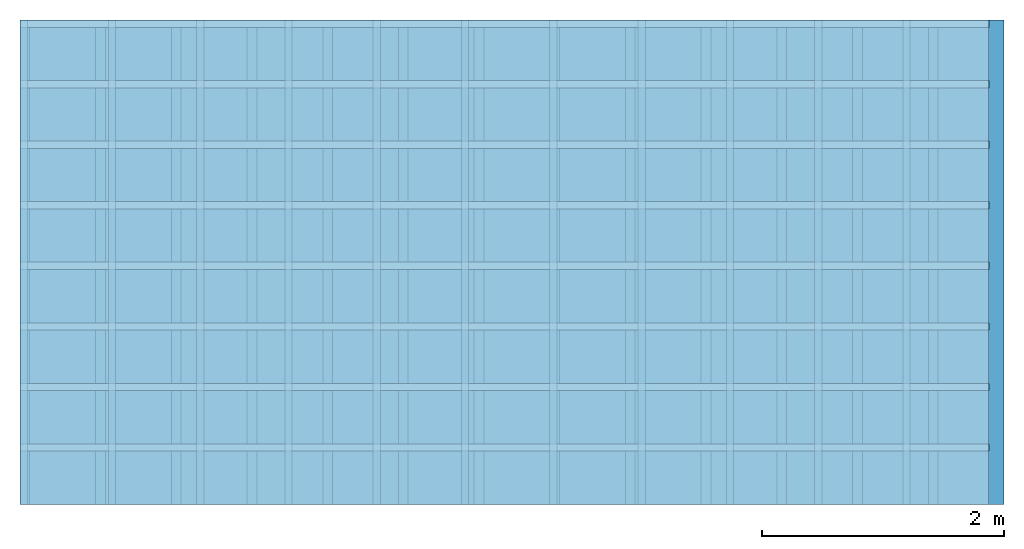
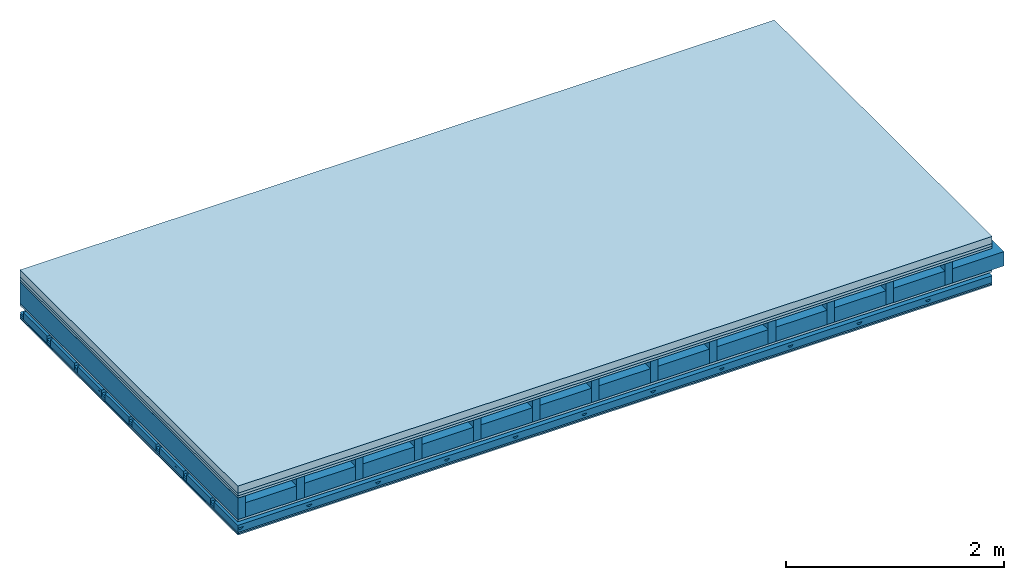
# One storey: 6 plates, 5 members, 1 element without a shape of its own.
"""IFC4 building model written with IfcOpenShell, lengths in metres."""

from ifc_helpers import new_model, si_unit, derived_unit, direction, frame, frame_2d, origin, origin_with_axes, place, context, project, spatial, polyline, rectangle, outline, extrude, material, layer, layer_set, type_object, element, aggregate, save


model = new_model("IFC4")

# Units and contexts
plan_context = context("Plan", 3, precision=1e-05, world=origin(), true_north=direction((0.0, 1.0)))
model_context = context("Model", 3, precision=1e-05, world=origin(), true_north=direction((0.0, 1.0)))
ifc_project = project(units=[si_unit("LENGTHUNIT", "METRE"), derived_unit("SOUNDPRESSUREUNIT", [(si_unit("PRESSUREUNIT", "PASCAL", prefix="MICRO"), 0)]), si_unit("ENERGYUNIT", "JOULE", prefix="MEGA"), si_unit("MASSUNIT", "GRAM", prefix="KILO"), derived_unit("THERMALTRANSMITTANCEUNIT", [(si_unit("POWERUNIT", "WATT"), 1), (si_unit("AREAUNIT", "SQUARE_METRE"), -1), (si_unit("THERMODYNAMICTEMPERATUREUNIT", "KELVIN"), -1)]), derived_unit("AREADENSITYUNIT", [(si_unit("MASSUNIT", "GRAM", prefix="KILO"), 1), (si_unit("AREAUNIT", "SQUARE_METRE"), -1)]), derived_unit("USERDEFINED", [(si_unit("ENERGYUNIT", "JOULE", prefix="MEGA"), 1), (si_unit("AREAUNIT", "SQUARE_METRE"), -1)])], contexts=[plan_context, model_context])

# Site, building, storey
site = spatial("IfcSite", under=ifc_project)
building_placement = place(None, origin())
building = spatial("IfcBuilding", under=site, at=building_placement)
storey_placement = place(building_placement, origin())
storey = spatial("IfcBuildingStorey", under=building, at=storey_placement)

# Slab, members, plates
ifc_material_1 = material(Name="Cement screed", Category="04.006")
ifc_layer_1 = layer(ifc_material_1, 0.08, Name="On-material")
ifc_material_2 = material()
ifc_layer_2 = layer(ifc_material_2, 0.03, Name="Impact sound insulation")
ifc_material_3 = material(Category="07.001")
ifc_layer_3 = layer(ifc_material_3, 0.025, Name="Sub-floor")
ifc_material_4 = material(Name="Rigid, of the art")
ifc_layer_4 = layer(ifc_material_4, 0.0, Name="Bond")
ifc_layer_5 = layer(None, 0.24, Name="Supporting structure")
ifc_layer_6 = layer(ifc_material_4, 0.0, Name="Bond")
ifc_layer_7 = layer(ifc_material_3, 0.025, Name="Lower layer 1")
ifc_layer_8 = layer(None, 0.093, Name="Coupling")
ifc_layer_9 = layer(None, 0.027, Name="Battens / profiles")
ifc_material_5 = material(Category="03.007")
ifc_layer_10 = layer(ifc_material_5, 0.015, Name="Ceiling covering 1st layer")
ifc_layer_11 = layer(ifc_material_5, 0.015, Name="Ceiling covering layer 2")
ifc_material_6 = material(Name="Glued joints")
ifc_layer_12 = layer(ifc_material_6, 0.0, Name="Surface / treatment")
ifc_layer_set = layer_set([ifc_layer_1, ifc_layer_2, ifc_layer_3, ifc_layer_4, ifc_layer_5, ifc_layer_6, ifc_layer_7, ifc_layer_8, ifc_layer_9, ifc_layer_10, ifc_layer_11, ifc_layer_12])
slab_type = type_object("IfcSlabType", Name="A0353", PredefinedType="NOTDEFINED", material=ifc_layer_set)
slab_placement = place(None, frame((0.0, 0.0, 0.0), z_axis=(0.0, 0.0, -1.0), x_axis=(1.0, 0.0, 0.0)))
slab = element("IfcSlab", 1, at=slab_placement, inside=storey, type_object=slab_type, material=ifc_layer_set, Name="Slab #1")
ifc_material_7 = material()
member_1_placement = place(slab_placement, origin())
member_1 = element("IfcMember", 2, at=member_1_placement, material=ifc_material_7, Name="Supporting structure", context=plan_context, shape_type="SweptSolid", body=[
    extrude(rectangle(XDim=0.08, YDim=0.24, at=frame_2d((0.04, 0.12), x_axis=(1.0, 0.0))), frame((0.0, 4.0, 0.135), z_axis=(0.0, -1.0, 0.0), x_axis=(1.0, 0.0, 0.0)), (0.0, 0.0, 1.0), 4.0),
    extrude(rectangle(XDim=0.08, YDim=0.24, at=frame_2d((0.04, 0.12), x_axis=(1.0, 0.0))), frame((0.625, 4.0, 0.135), z_axis=(0.0, -1.0, 0.0), x_axis=(1.0, 0.0, 0.0)), (0.0, 0.0, 1.0), 4.0),
    extrude(rectangle(XDim=0.08, YDim=0.24, at=frame_2d((0.04, 0.12), x_axis=(1.0, 0.0))), frame((1.25, 4.0, 0.135), z_axis=(0.0, -1.0, 0.0), x_axis=(1.0, 0.0, 0.0)), (0.0, 0.0, 1.0), 4.0),
    extrude(rectangle(XDim=0.08, YDim=0.24, at=frame_2d((0.04, 0.12), x_axis=(1.0, 0.0))), frame((1.875, 4.0, 0.135), z_axis=(0.0, -1.0, 0.0), x_axis=(1.0, 0.0, 0.0)), (0.0, 0.0, 1.0), 4.0),
    extrude(rectangle(XDim=0.08, YDim=0.24, at=frame_2d((0.04, 0.12), x_axis=(1.0, 0.0))), frame((2.5, 4.0, 0.135), z_axis=(0.0, -1.0, 0.0), x_axis=(1.0, 0.0, 0.0)), (0.0, 0.0, 1.0), 4.0),
    extrude(rectangle(XDim=0.08, YDim=0.24, at=frame_2d((0.04, 0.12), x_axis=(1.0, 0.0))), frame((3.125, 4.0, 0.135), z_axis=(0.0, -1.0, 0.0), x_axis=(1.0, 0.0, 0.0)), (0.0, 0.0, 1.0), 4.0),
    extrude(rectangle(XDim=0.08, YDim=0.24, at=frame_2d((0.04, 0.12), x_axis=(1.0, 0.0))), frame((3.75, 4.0, 0.135), z_axis=(0.0, -1.0, 0.0), x_axis=(1.0, 0.0, 0.0)), (0.0, 0.0, 1.0), 4.0),
    extrude(rectangle(XDim=0.08, YDim=0.24, at=frame_2d((0.04, 0.12), x_axis=(1.0, 0.0))), frame((4.375, 4.0, 0.135), z_axis=(0.0, -1.0, 0.0), x_axis=(1.0, 0.0, 0.0)), (0.0, 0.0, 1.0), 4.0),
    extrude(rectangle(XDim=0.08, YDim=0.24, at=frame_2d((0.04, 0.12), x_axis=(1.0, 0.0))), frame((5.0, 4.0, 0.135), z_axis=(0.0, -1.0, 0.0), x_axis=(1.0, 0.0, 0.0)), (0.0, 0.0, 1.0), 4.0),
    extrude(rectangle(XDim=0.08, YDim=0.24, at=frame_2d((0.04, 0.12), x_axis=(1.0, 0.0))), frame((5.625, 4.0, 0.135), z_axis=(0.0, -1.0, 0.0), x_axis=(1.0, 0.0, 0.0)), (0.0, 0.0, 1.0), 4.0),
    extrude(rectangle(XDim=0.08, YDim=0.24, at=frame_2d((0.04, 0.12), x_axis=(1.0, 0.0))), frame((6.25, 4.0, 0.135), z_axis=(0.0, -1.0, 0.0), x_axis=(1.0, 0.0, 0.0)), (0.0, 0.0, 1.0), 4.0),
    extrude(rectangle(XDim=0.08, YDim=0.24, at=frame_2d((0.04, 0.12), x_axis=(1.0, 0.0))), frame((6.875, 4.0, 0.135), z_axis=(0.0, -1.0, 0.0), x_axis=(1.0, 0.0, 0.0)), (0.0, 0.0, 1.0), 4.0),
    extrude(rectangle(XDim=0.08, YDim=0.24, at=frame_2d((0.04, 0.12), x_axis=(1.0, 0.0))), frame((7.5, 4.0, 0.135), z_axis=(0.0, -1.0, 0.0), x_axis=(1.0, 0.0, 0.0)), (0.0, 0.0, 1.0), 4.0),
])
ifc_material_8 = material()
member_2_placement = place(slab_placement, origin())
member_2 = element("IfcMember", 3, at=member_2_placement, material=ifc_material_8, Name="Cavity", context=plan_context, shape_type="SweptSolid", body=[
    extrude(rectangle(XDim=0.545, YDim=0.16, at=frame_2d((0.2725, 0.08), x_axis=(1.0, 0.0))), frame((0.08, 4.0, 0.215), z_axis=(0.0, -1.0, 0.0), x_axis=(1.0, 0.0, 0.0)), (0.0, 0.0, 1.0), 4.0),
    extrude(rectangle(XDim=0.545, YDim=0.16, at=frame_2d((0.2725, 0.08), x_axis=(1.0, 0.0))), frame((0.705, 4.0, 0.215), z_axis=(0.0, -1.0, 0.0), x_axis=(1.0, 0.0, 0.0)), (0.0, 0.0, 1.0), 4.0),
    extrude(rectangle(XDim=0.545, YDim=0.16, at=frame_2d((0.2725, 0.08), x_axis=(1.0, 0.0))), frame((1.33, 4.0, 0.215), z_axis=(0.0, -1.0, 0.0), x_axis=(1.0, 0.0, 0.0)), (0.0, 0.0, 1.0), 4.0),
    extrude(rectangle(XDim=0.545, YDim=0.16, at=frame_2d((0.2725, 0.08), x_axis=(1.0, 0.0))), frame((1.955, 4.0, 0.215), z_axis=(0.0, -1.0, 0.0), x_axis=(1.0, 0.0, 0.0)), (0.0, 0.0, 1.0), 4.0),
    extrude(rectangle(XDim=0.545, YDim=0.16, at=frame_2d((0.2725, 0.08), x_axis=(1.0, 0.0))), frame((2.58, 4.0, 0.215), z_axis=(0.0, -1.0, 0.0), x_axis=(1.0, 0.0, 0.0)), (0.0, 0.0, 1.0), 4.0),
    extrude(rectangle(XDim=0.545, YDim=0.16, at=frame_2d((0.2725, 0.08), x_axis=(1.0, 0.0))), frame((3.205, 4.0, 0.215), z_axis=(0.0, -1.0, 0.0), x_axis=(1.0, 0.0, 0.0)), (0.0, 0.0, 1.0), 4.0),
    extrude(rectangle(XDim=0.545, YDim=0.16, at=frame_2d((0.2725, 0.08), x_axis=(1.0, 0.0))), frame((3.83, 4.0, 0.215), z_axis=(0.0, -1.0, 0.0), x_axis=(1.0, 0.0, 0.0)), (0.0, 0.0, 1.0), 4.0),
    extrude(rectangle(XDim=0.545, YDim=0.16, at=frame_2d((0.2725, 0.08), x_axis=(1.0, 0.0))), frame((4.455, 4.0, 0.215), z_axis=(0.0, -1.0, 0.0), x_axis=(1.0, 0.0, 0.0)), (0.0, 0.0, 1.0), 4.0),
    extrude(rectangle(XDim=0.545, YDim=0.16, at=frame_2d((0.2725, 0.08), x_axis=(1.0, 0.0))), frame((5.08, 4.0, 0.215), z_axis=(0.0, -1.0, 0.0), x_axis=(1.0, 0.0, 0.0)), (0.0, 0.0, 1.0), 4.0),
    extrude(rectangle(XDim=0.545, YDim=0.16, at=frame_2d((0.2725, 0.08), x_axis=(1.0, 0.0))), frame((5.705, 4.0, 0.215), z_axis=(0.0, -1.0, 0.0), x_axis=(1.0, 0.0, 0.0)), (0.0, 0.0, 1.0), 4.0),
    extrude(rectangle(XDim=0.545, YDim=0.16, at=frame_2d((0.2725, 0.08), x_axis=(1.0, 0.0))), frame((6.33, 4.0, 0.215), z_axis=(0.0, -1.0, 0.0), x_axis=(1.0, 0.0, 0.0)), (0.0, 0.0, 1.0), 4.0),
    extrude(rectangle(XDim=0.545, YDim=0.16, at=frame_2d((0.2725, 0.08), x_axis=(1.0, 0.0))), frame((6.955, 4.0, 0.215), z_axis=(0.0, -1.0, 0.0), x_axis=(1.0, 0.0, 0.0)), (0.0, 0.0, 1.0), 4.0),
    extrude(rectangle(XDim=0.545, YDim=0.16, at=frame_2d((0.2725, 0.08), x_axis=(1.0, 0.0))), frame((7.58, 4.0, 0.215), z_axis=(0.0, -1.0, 0.0), x_axis=(1.0, 0.0, 0.0)), (0.0, 0.0, 1.0), 4.0),
])
ifc_material_9 = material()
member_3_placement = place(slab_placement, origin())
member_3 = element("IfcMember", 4, at=member_3_placement, material=ifc_material_9, Name="Coupling", context=plan_context, shape_type="SweptSolid", body=[
    extrude(outline(polyline([(0.0, 0.0), (0.06, 0.0), (0.04, 0.02), (0.02, 0.02), (0.0, 0.0)])), frame((0.0, 4.0, 0.473), z_axis=(0.0, -1.0, 0.0), x_axis=(1.0, 0.0, 0.0)), (0.0, 0.0, 1.0), 4.0),
    extrude(outline(polyline([(0.0, 0.0), (0.06, 0.0), (0.04, 0.02), (0.02, 0.02), (0.0, 0.0)])), frame((0.729, 4.0, 0.473), z_axis=(0.0, -1.0, 0.0), x_axis=(1.0, 0.0, 0.0)), (0.0, 0.0, 1.0), 4.0),
    extrude(outline(polyline([(0.0, 0.0), (0.06, 0.0), (0.04, 0.02), (0.02, 0.02), (0.0, 0.0)])), frame((1.458, 4.0, 0.473), z_axis=(0.0, -1.0, 0.0), x_axis=(1.0, 0.0, 0.0)), (0.0, 0.0, 1.0), 4.0),
    extrude(outline(polyline([(0.0, 0.0), (0.06, 0.0), (0.04, 0.02), (0.02, 0.02), (0.0, 0.0)])), frame((2.187, 4.0, 0.473), z_axis=(0.0, -1.0, 0.0), x_axis=(1.0, 0.0, 0.0)), (0.0, 0.0, 1.0), 4.0),
    extrude(outline(polyline([(0.0, 0.0), (0.06, 0.0), (0.04, 0.02), (0.02, 0.02), (0.0, 0.0)])), frame((2.916, 4.0, 0.473), z_axis=(0.0, -1.0, 0.0), x_axis=(1.0, 0.0, 0.0)), (0.0, 0.0, 1.0), 4.0),
    extrude(outline(polyline([(0.0, 0.0), (0.06, 0.0), (0.04, 0.02), (0.02, 0.02), (0.0, 0.0)])), frame((3.645, 4.0, 0.473), z_axis=(0.0, -1.0, 0.0), x_axis=(1.0, 0.0, 0.0)), (0.0, 0.0, 1.0), 4.0),
    extrude(outline(polyline([(0.0, 0.0), (0.06, 0.0), (0.04, 0.02), (0.02, 0.02), (0.0, 0.0)])), frame((4.374, 4.0, 0.473), z_axis=(0.0, -1.0, 0.0), x_axis=(1.0, 0.0, 0.0)), (0.0, 0.0, 1.0), 4.0),
    extrude(outline(polyline([(0.0, 0.0), (0.06, 0.0), (0.04, 0.02), (0.02, 0.02), (0.0, 0.0)])), frame((5.103, 4.0, 0.473), z_axis=(0.0, -1.0, 0.0), x_axis=(1.0, 0.0, 0.0)), (0.0, 0.0, 1.0), 4.0),
    extrude(outline(polyline([(0.0, 0.0), (0.06, 0.0), (0.04, 0.02), (0.02, 0.02), (0.0, 0.0)])), frame((5.832, 4.0, 0.473), z_axis=(0.0, -1.0, 0.0), x_axis=(1.0, 0.0, 0.0)), (0.0, 0.0, 1.0), 4.0),
    extrude(outline(polyline([(0.0, 0.0), (0.06, 0.0), (0.04, 0.02), (0.02, 0.02), (0.0, 0.0)])), frame((6.561, 4.0, 0.473), z_axis=(0.0, -1.0, 0.0), x_axis=(1.0, 0.0, 0.0)), (0.0, 0.0, 1.0), 4.0),
    extrude(outline(polyline([(0.0, 0.0), (0.06, 0.0), (0.04, 0.02), (0.02, 0.02), (0.0, 0.0)])), frame((7.29, 4.0, 0.473), z_axis=(0.0, -1.0, 0.0), x_axis=(1.0, 0.0, 0.0)), (0.0, 0.0, 1.0), 4.0),
])
ifc_material_10 = material()
member_4_placement = place(slab_placement, origin())
member_4 = element("IfcMember", 5, at=member_4_placement, material=ifc_material_10, Name="Battens / profiles", context=plan_context, shape_type="SweptSolid", body=[
    extrude(rectangle(XDim=0.06, YDim=0.027, at=frame_2d((0.03, 0.0135), x_axis=(1.0, 0.0))), frame((0.0, 0.0, 0.493), z_axis=(1.0, 0.0, 0.0), x_axis=(0.0, 1.0, 0.0)), (0.0, 0.0, 1.0), 8.0),
    extrude(rectangle(XDim=0.06, YDim=0.027, at=frame_2d((0.03, 0.0135), x_axis=(1.0, 0.0))), frame((0.0, 0.5, 0.493), z_axis=(1.0, 0.0, 0.0), x_axis=(0.0, 1.0, 0.0)), (0.0, 0.0, 1.0), 8.0),
    extrude(rectangle(XDim=0.06, YDim=0.027, at=frame_2d((0.03, 0.0135), x_axis=(1.0, 0.0))), frame((0.0, 1.0, 0.493), z_axis=(1.0, 0.0, 0.0), x_axis=(0.0, 1.0, 0.0)), (0.0, 0.0, 1.0), 8.0),
    extrude(rectangle(XDim=0.06, YDim=0.027, at=frame_2d((0.03, 0.0135), x_axis=(1.0, 0.0))), frame((0.0, 1.5, 0.493), z_axis=(1.0, 0.0, 0.0), x_axis=(0.0, 1.0, 0.0)), (0.0, 0.0, 1.0), 8.0),
    extrude(rectangle(XDim=0.06, YDim=0.027, at=frame_2d((0.03, 0.0135), x_axis=(1.0, 0.0))), frame((0.0, 2.0, 0.493), z_axis=(1.0, 0.0, 0.0), x_axis=(0.0, 1.0, 0.0)), (0.0, 0.0, 1.0), 8.0),
    extrude(rectangle(XDim=0.06, YDim=0.027, at=frame_2d((0.03, 0.0135), x_axis=(1.0, 0.0))), frame((0.0, 2.5, 0.493), z_axis=(1.0, 0.0, 0.0), x_axis=(0.0, 1.0, 0.0)), (0.0, 0.0, 1.0), 8.0),
    extrude(rectangle(XDim=0.06, YDim=0.027, at=frame_2d((0.03, 0.0135), x_axis=(1.0, 0.0))), frame((0.0, 3.0, 0.493), z_axis=(1.0, 0.0, 0.0), x_axis=(0.0, 1.0, 0.0)), (0.0, 0.0, 1.0), 8.0),
    extrude(rectangle(XDim=0.06, YDim=0.027, at=frame_2d((0.03, 0.0135), x_axis=(1.0, 0.0))), frame((0.0, 3.5, 0.493), z_axis=(1.0, 0.0, 0.0), x_axis=(0.0, 1.0, 0.0)), (0.0, 0.0, 1.0), 8.0),
])
member_5_placement = place(slab_placement, origin())
member_5 = element("IfcMember", 6, at=member_5_placement, material=ifc_material_8, Name="Cavity", context=plan_context, shape_type="SweptSolid", body=[
    extrude(rectangle(XDim=0.44, YDim=0.08, at=frame_2d((0.22, 0.04), x_axis=(1.0, 0.0))), frame((0.0, 0.06, 0.44), z_axis=(1.0, 0.0, 0.0), x_axis=(0.0, 1.0, 0.0)), (0.0, 0.0, 1.0), 8.0),
    extrude(rectangle(XDim=0.44, YDim=0.08, at=frame_2d((0.22, 0.04), x_axis=(1.0, 0.0))), frame((0.0, 0.56, 0.44), z_axis=(1.0, 0.0, 0.0), x_axis=(0.0, 1.0, 0.0)), (0.0, 0.0, 1.0), 8.0),
    extrude(rectangle(XDim=0.44, YDim=0.08, at=frame_2d((0.22, 0.04), x_axis=(1.0, 0.0))), frame((0.0, 1.06, 0.44), z_axis=(1.0, 0.0, 0.0), x_axis=(0.0, 1.0, 0.0)), (0.0, 0.0, 1.0), 8.0),
    extrude(rectangle(XDim=0.44, YDim=0.08, at=frame_2d((0.22, 0.04), x_axis=(1.0, 0.0))), frame((0.0, 1.56, 0.44), z_axis=(1.0, 0.0, 0.0), x_axis=(0.0, 1.0, 0.0)), (0.0, 0.0, 1.0), 8.0),
    extrude(rectangle(XDim=0.44, YDim=0.08, at=frame_2d((0.22, 0.04), x_axis=(1.0, 0.0))), frame((0.0, 2.06, 0.44), z_axis=(1.0, 0.0, 0.0), x_axis=(0.0, 1.0, 0.0)), (0.0, 0.0, 1.0), 8.0),
    extrude(rectangle(XDim=0.44, YDim=0.08, at=frame_2d((0.22, 0.04), x_axis=(1.0, 0.0))), frame((0.0, 2.56, 0.44), z_axis=(1.0, 0.0, 0.0), x_axis=(0.0, 1.0, 0.0)), (0.0, 0.0, 1.0), 8.0),
    extrude(rectangle(XDim=0.44, YDim=0.08, at=frame_2d((0.22, 0.04), x_axis=(1.0, 0.0))), frame((0.0, 3.06, 0.44), z_axis=(1.0, 0.0, 0.0), x_axis=(0.0, 1.0, 0.0)), (0.0, 0.0, 1.0), 8.0),
    extrude(rectangle(XDim=0.44, YDim=0.08, at=frame_2d((0.22, 0.04), x_axis=(1.0, 0.0))), frame((0.0, 3.56, 0.44), z_axis=(1.0, 0.0, 0.0), x_axis=(0.0, 1.0, 0.0)), (0.0, 0.0, 1.0), 8.0),
])
plate_1_placement = place(slab_placement, origin())
plate_1 = element("IfcPlate", 7, at=plate_1_placement, material=ifc_material_1, Name="On-material", context=plan_context, shape_type="SweptSolid", body=[
    extrude(rectangle(XDim=8.0, YDim=4.0, at=frame_2d((4.0, 2.0), x_axis=(1.0, 0.0))), origin_with_axes(), (0.0, 0.0, 1.0), 0.08),
])
plate_2_placement = place(slab_placement, origin())
plate_2 = element("IfcPlate", 8, at=plate_2_placement, material=ifc_material_2, Name="Impact sound insulation", context=plan_context, shape_type="SweptSolid", body=[
    extrude(rectangle(XDim=8.0, YDim=4.0, at=frame_2d((4.0, 2.0), x_axis=(1.0, 0.0))), frame((0.0, 0.0, 0.08), z_axis=(0.0, 0.0, 1.0), x_axis=(1.0, 0.0, 0.0)), (0.0, 0.0, 1.0), 0.03),
])
plate_3_placement = place(slab_placement, origin())
plate_3 = element("IfcPlate", 9, at=plate_3_placement, material=ifc_material_3, Name="Sub-floor", context=plan_context, shape_type="SweptSolid", body=[
    extrude(rectangle(XDim=8.0, YDim=4.0, at=frame_2d((4.0, 2.0), x_axis=(1.0, 0.0))), frame((0.0, 0.0, 0.11), z_axis=(0.0, 0.0, 1.0), x_axis=(1.0, 0.0, 0.0)), (0.0, 0.0, 1.0), 0.025),
])
plate_4_placement = place(slab_placement, origin())
plate_4 = element("IfcPlate", 10, at=plate_4_placement, material=ifc_material_3, Name="Lower layer 1", context=plan_context, shape_type="SweptSolid", body=[
    extrude(rectangle(XDim=8.0, YDim=4.0, at=frame_2d((4.0, 2.0), x_axis=(1.0, 0.0))), frame((0.0, 0.0, 0.375), z_axis=(0.0, 0.0, 1.0), x_axis=(1.0, 0.0, 0.0)), (0.0, 0.0, 1.0), 0.025),
])
plate_5_placement = place(slab_placement, origin())
plate_5 = element("IfcPlate", 11, at=plate_5_placement, material=ifc_material_5, Name="Ceiling covering 1st layer", context=plan_context, shape_type="SweptSolid", body=[
    extrude(rectangle(XDim=8.0, YDim=4.0, at=frame_2d((4.0, 2.0), x_axis=(1.0, 0.0))), frame((0.0, 0.0, 0.52), z_axis=(0.0, 0.0, 1.0), x_axis=(1.0, 0.0, 0.0)), (0.0, 0.0, 1.0), 0.015),
])
plate_6_placement = place(slab_placement, origin())
plate_6 = element("IfcPlate", 12, at=plate_6_placement, material=ifc_material_5, Name="Ceiling covering layer 2", context=plan_context, shape_type="SweptSolid", body=[
    extrude(rectangle(XDim=8.0, YDim=4.0, at=frame_2d((4.0, 2.0), x_axis=(1.0, 0.0))), frame((0.0, 0.0, 0.535), z_axis=(0.0, 0.0, 1.0), x_axis=(1.0, 0.0, 0.0)), (0.0, 0.0, 1.0), 0.015),
])
aggregate(slab, [plate_1, plate_2, plate_3, member_1, member_2, plate_4, member_3, member_4, member_5, plate_5, plate_6])

save(model, "model.ifc")
